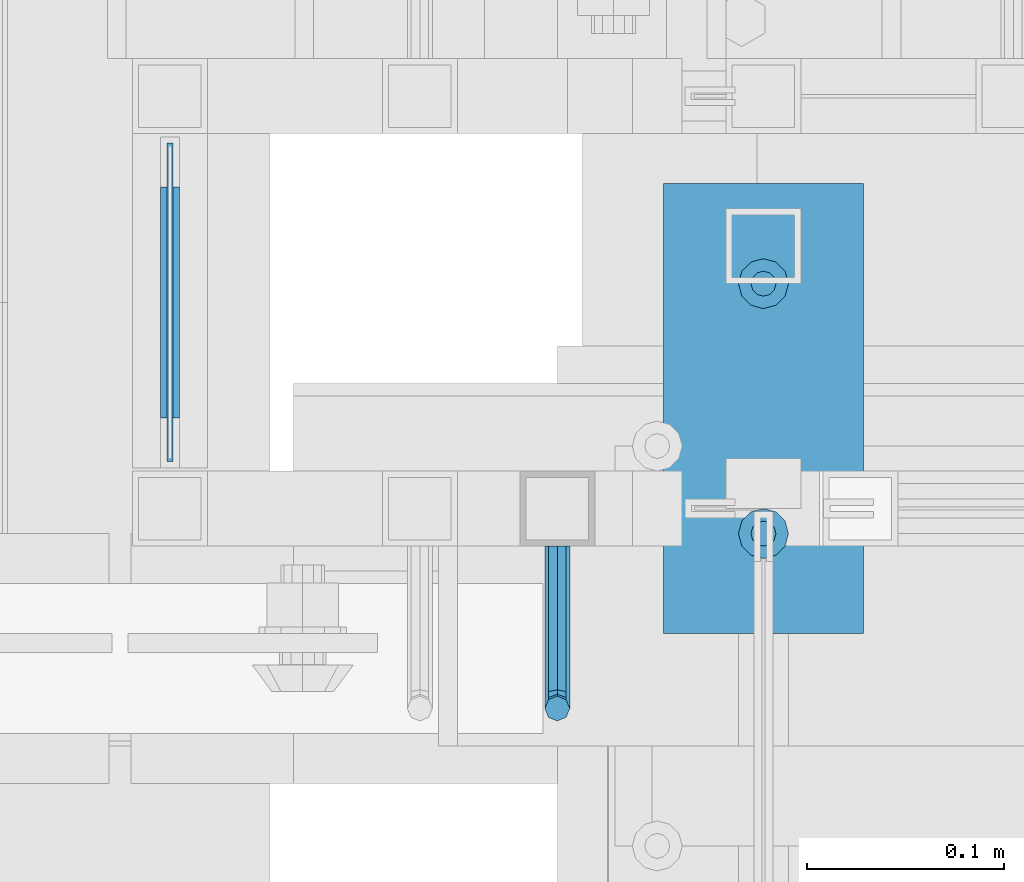
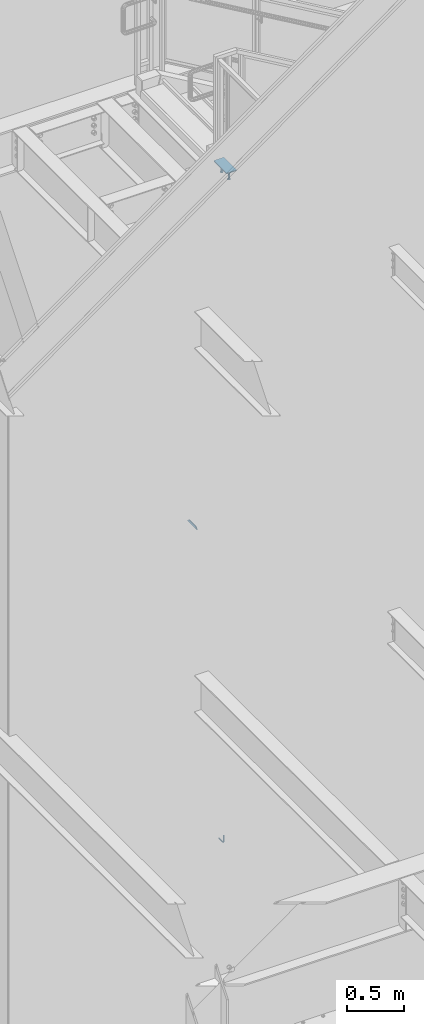
# One storey, part 907 of 1179: 5 beams, 3 elements without a shape of their own.
"""IFC2X3 building model written with IfcOpenShell, lengths in millimetres."""

from ifc_helpers import new_model, si_unit, frame, origin_with_axes, place, context, subcontext, project, spatial, faceted_brep, material, type_object, element, aggregate, save


model = new_model("IFC2X3")

# Units and contexts
model_context = context("Model", 3, precision=1e-05, world=origin_with_axes())
body_context = subcontext(model_context, "Body", "Model", "MODEL_VIEW")
ifc_project = project(units=[si_unit("LENGTHUNIT", "METRE", prefix="MILLI"), si_unit("AREAUNIT", "SQUARE_METRE"), si_unit("VOLUMEUNIT", "CUBIC_METRE"), si_unit("MASSUNIT", "GRAM", prefix="KILO"), si_unit("TIMEUNIT", "SECOND"), si_unit("PLANEANGLEUNIT", "RADIAN"), si_unit("SOLIDANGLEUNIT", "STERADIAN"), si_unit("THERMODYNAMICTEMPERATUREUNIT", "DEGREE_CELSIUS"), si_unit("LUMINOUSINTENSITYUNIT", "LUMEN")], contexts=[model_context])

# Site, building, storey
site_placement = place(None, origin_with_axes())
site = spatial("IfcSite", under=ifc_project, at=site_placement, CompositionType="ELEMENT")
building_placement = place(site_placement, origin_with_axes())
building = spatial("IfcBuilding", under=site, at=building_placement, Name="Undefined", CompositionType="ELEMENT")
storey_placement = place(building_placement, origin_with_axes())
storey = spatial("IfcBuildingStorey", under=building, at=storey_placement, Name="Undefined", CompositionType="ELEMENT", Elevation=0.0)

# Assembly, beam
assembly_1_placement = place(storey_placement, origin_with_axes())
assembly_1 = element("IfcElementAssembly", 1, at=assembly_1_placement, inside=storey, Name="GUARDRAIL", AssemblyPlace="NOTDEFINED", PredefinedType="RIGID_FRAME")
ifc_material_1 = material(Name="STEEL/BUY-OUT")
beam_type_1 = type_object("IfcBeamType", PredefinedType="NOTDEFINED")
beam_1_placement = place(assembly_1_placement, frame((19307.1749999845, 39563.6750015464, 4376.7375008146), z_axis=(0.0, -1.0, 0.0), x_axis=(0.0, 0.0, -1.0)))
beam_1 = element("IfcBeam", 2, at=beam_1_placement, type_object=beam_type_1, material=ifc_material_1, Name="U-EDGE", context=body_context, shape_type="Brep", body=[
    faceted_brep([(0.0, 1.58750000000146, 46.037500944738), (0.0, -1.58750000000146, 46.037500944738), (22.2250000381364, -1.58750000000146, 68.2625008571486), (22.2250000381364, -4.76249999999709, 68.2625008571486), (7.59955582907423e-08, -4.76249999999709, 46.0375010207354), (7.59955582907423e-08, -7.9375, 46.0375010207354), (25.4000000381357, -7.9375, 71.4375008391871), (25.4000000381357, 1.58750000000146, 71.4375008391871), (25.4000000381357, -7.9375, -96.8375000000015), (25.4000000381357, 1.58750000000146, -96.8375000000015), (0.0, 1.58750000000146, -71.4374998076601), (0.0, -1.58750000000146, -71.4374998076601), (22.2250000381364, -1.58750000000146, -93.6624999715204), (22.2250000381364, -4.76249999999709, -93.6624999715204), (7.59955582907423e-08, -4.76249999999709, -71.4374998836502), (7.59955582907423e-08, -7.9375, -71.4374998836502)], [[[0, 1, 2, 3, 4, 5, 6, 7]], [[7, 6, 8, 9]], [[0, 7, 9, 10]], [[1, 0, 10, 11]], [[2, 1, 11, 12]], [[3, 2, 12, 13]], [[4, 3, 13, 14]], [[5, 4, 14, 15]], [[6, 5, 15, 8]], [[14, 13, 12, 11, 10, 9, 8, 15]]]),
])
aggregate(assembly_1, [beam_1])

assembly_2_placement = place(storey_placement, origin_with_axes())
assembly_2 = element("IfcElementAssembly", 3, at=assembly_2_placement, inside=storey, Name="GUARDRAIL", AssemblyPlace="NOTDEFINED", PredefinedType="RIGID_FRAME")
ifc_material_2 = material(Name="STEEL/A36")
beam_type_2 = type_object("IfcBeamType", PredefinedType="NOTDEFINED")
beam_2_placement = place(assembly_2_placement, frame((19500.850000416, 39452.5499999814, 992.664373870646), z_axis=(0.0, 0.0, 1.0), x_axis=(0.0, -1.0, 0.0)))
beam_2 = element("IfcBeam", 4, at=beam_2_placement, type_object=beam_type_2, material=ifc_material_2, Name="BRACKET", context=body_context, shape_type="Brep", body=[
    faceted_brep([(0.0, 0.0, 6.34999999999991), (0.0, -4.49012806053361, 4.49012806053452), (69.849999425729, -4.49012806053361, 4.49012806053452), (69.849999425729, 0.0, 6.34999999999991), (0.0, 4.49012806053361, 4.49012806053452), (69.849999425729, 4.49012806053361, 4.49012806053452), (0.0, 6.34999999999854, 0.0), (69.849999425729, 6.34999999999854, 0.0), (0.0, 4.49012806053361, -4.49012806053452), (69.849999425729, 4.49012806053361, -4.49012806053452), (0.0, 0.0, -6.34999999999991), (69.849999425729, 0.0, -6.34999999999991), (0.0, -4.49012806053361, -4.49012806053452), (69.849999425729, -4.49012806053361, -4.49012806053452), (0.0, -6.34999999999854, 0.0), (69.849999425729, -6.34999999999854, 0.0), (76.1999993303689, -6.34999999999854, 1.70147734638658), (73.9549353000984, -4.49012806053361, 5.59004231305425), (73.024999330366, 0.0, 7.20073866041639), (73.9549353000984, 4.49012806053361, 5.59004231305425), (76.1999993303689, 6.34999999999854, 1.70147734638658), (78.445063360632, 4.49012806053361, -2.18708762028064), (79.3749993303718, 0.0, -3.79778396764323), (78.445063360632, -4.49012806053361, -2.18708762028064), (84.7370868552753, 4.49012806053361, 4.10493587436031), (87.0401272955278, 4.49012806053361, 12.6999998092651), (88.8999992349927, 0.0, 12.6999998092651), (86.3477832026401, 0.0, 3.17499990462693), (80.8485218886053, 6.34999999999854, 6.34999990462893), (82.5499992349942, 6.34999999999854, 12.6999998092651), (76.9599569219426, 4.49012806053361, 8.59506393489755), (78.0598711744606, 4.49012806053361, 12.6999998092651), (75.3492605745778, 0.0, 9.52499990463093), (76.1999992349956, 0.0, 12.6999998092651), (76.9599569219426, -4.49012806053361, 8.59506393489755), (78.0598711744606, -4.49012806053361, 12.6999998092651), (80.8485218886053, -6.34999999999854, 6.34999990462893), (82.5499992349942, -6.34999999999854, 12.6999998092651), (84.7370868552753, -4.49012806053361, 4.10493587436031), (87.0401272955278, -4.49012806053361, 12.6999998092651), (88.8999992349927, 0.0, 76.2000000000003), (87.0401280961523, -4.4901280621234, 73.5807586148453), (82.5500000355751, -6.35000000147556, 72.4958333104305), (78.0598719750778, -4.4901280619415, 73.5807586149517), (76.1999992349956, 0.0, 76.2000000000003), (78.0598719752597, 4.49012805902021, 78.8192413833694), (82.550000035837, 6.34999999837237, 79.9041666931562), (87.0401280963342, 4.49012805883831, 78.819241383263)], [[[0, 1, 2, 3]], [[4, 0, 3, 5]], [[6, 4, 5, 7]], [[8, 6, 7, 9]], [[10, 8, 9, 11]], [[12, 10, 11, 13]], [[1, 0, 4, 6, 8, 10, 12, 14]], [[1, 14, 15, 2]], [[14, 12, 13, 15]], [[2, 15, 16, 17]], [[3, 2, 17, 18]], [[5, 3, 18, 19]], [[7, 5, 19, 20]], [[9, 7, 20, 21]], [[11, 9, 21, 22]], [[13, 11, 22, 23]], [[24, 25, 26, 27]], [[28, 29, 25, 24]], [[30, 31, 29, 28]], [[32, 33, 31, 30]], [[34, 35, 33, 32]], [[36, 37, 35, 34]], [[38, 39, 37, 36]], [[27, 26, 39, 38]], [[22, 27, 38, 23]], [[21, 24, 27, 22]], [[20, 28, 24, 21]], [[19, 30, 28, 20]], [[18, 32, 30, 19]], [[17, 34, 32, 18]], [[16, 36, 34, 17]], [[23, 38, 36, 16]], [[15, 13, 23, 16]], [[39, 26, 40, 41]], [[37, 39, 41, 42]], [[35, 37, 42, 43]], [[33, 35, 43, 44]], [[31, 33, 44, 45]], [[29, 31, 45, 46]], [[25, 29, 46, 47]], [[26, 25, 47, 40]], [[46, 45, 44, 43, 42, 41, 40, 47]]]),
])
aggregate(assembly_2, [beam_2])

# Assembly, beams
assembly_3_placement = place(storey_placement, origin_with_axes())
assembly_3 = element("IfcElementAssembly", 5, at=assembly_3_placement, inside=storey, Name="EMBED", AssemblyPlace="NOTDEFINED", PredefinedType="RIGID_FRAME")
ifc_material_3 = material(Name="STEEL/A108")
beam_type_3 = type_object("IfcBeamType", Name="STUD_1/2-DIA", PredefinedType="NOTDEFINED")
beam_3_placement = place(assembly_3_placement, frame((19605.625, 39458.900000798, 8137.525), z_axis=(0.0, -1.0, 0.0), x_axis=(0.0, 0.0, -1.0)))
beam_3 = element("IfcBeam", 6, at=beam_3_placement, type_object=beam_type_3, material=ifc_material_3, Name="SHEAR STUD", ObjectType="STUD_1/2-DIA", context=body_context, shape_type="Brep", body=[
    faceted_brep([(0.0, -3.1800000667572, 5.5), (0.0, -5.5, 3.1800000667572), (94.4880000000003, -5.5, 3.1800000667572), (94.4880000000003, -3.1800000667572, 5.5), (0.0, -6.34999999999854, 0.0), (94.4880000000003, -6.34999990463257, 0.0), (0.0, -5.5, -3.1800000667572), (94.4880000000003, -5.5, -3.1800000667572), (0.0, -3.1800000667572, -5.5), (94.4880000000003, -3.1800000667572, -5.5), (0.0, 0.0, -6.34999999999991), (94.4880000000003, 0.0, -6.34999990463257), (0.0, 3.1800000667572, -5.5), (94.4880000000003, 3.1800000667572, -5.5), (0.0, 5.5, -3.1800000667572), (94.4880000000003, 5.5, -3.1800000667572), (0.0, 6.34999999999854, 0.0), (94.4880000000003, 6.34999990463257, 0.0), (0.0, 5.5, 3.1800000667572), (94.4880000000003, 5.5, 3.1800000667572), (0.0, 3.1800000667572, 5.5), (94.4880000000003, 3.1800000667572, 5.5), (0.0, 0.0, 6.34999999999991), (94.4880000000003, 0.0, 6.34999990463257), (96.5200000000004, -10.9899997711182, 6.34999990463257), (96.5200000000004, -6.34000015258789, 10.9899997711182), (96.5200000000004, -12.6999998092651, 0.0), (96.5200000000004, -10.9899997711182, -6.34999990463257), (96.5200000000004, -6.34000015258789, -10.9899997711182), (96.5200000000004, 0.0, -12.6899995803833), (96.5200000000004, 6.34000015258789, -10.9899997711182), (96.5200000000004, 10.9899997711182, -6.34999990463257), (96.5200000000004, 12.6999998092651, 0.0), (96.5200000000004, 10.9899997711182, 6.34999990463257), (96.5200000000004, 6.34000015258789, 10.9899997711182), (96.5200000000004, 0.0, 12.6899995803833), (101.6, -10.9899997711182, 6.34999990463257), (101.6, -6.34000015258789, 10.9899997711182), (101.6, -12.6999998092651, 0.0), (101.6, -10.9899997711182, -6.34999990463257), (101.6, -6.34000015258789, -10.9899997711182), (101.6, 0.0, -12.6899995803833), (101.6, 6.34000015258789, -10.9899997711182), (101.6, 10.9899997711182, -6.34999990463257), (101.6, 12.6999998092651, 0.0), (101.6, 10.9899997711182, 6.34999990463257), (101.6, 6.34000015258789, 10.9899997711182), (101.6, 0.0, 12.6899995803833)], [[[0, 1, 2, 3]], [[1, 4, 5, 2]], [[4, 6, 7, 5]], [[6, 8, 9, 7]], [[8, 10, 11, 9]], [[10, 12, 13, 11]], [[12, 14, 15, 13]], [[14, 16, 17, 15]], [[16, 18, 19, 17]], [[18, 20, 21, 19]], [[20, 22, 23, 21]], [[22, 0, 3, 23]], [[22, 20, 18, 16, 14, 12, 10, 8, 6, 4, 1, 0]], [[3, 2, 24, 25]], [[2, 5, 26, 24]], [[5, 7, 27, 26]], [[7, 9, 28, 27]], [[9, 11, 29, 28]], [[11, 13, 30, 29]], [[13, 15, 31, 30]], [[15, 17, 32, 31]], [[17, 19, 33, 32]], [[19, 21, 34, 33]], [[21, 23, 35, 34]], [[23, 3, 25, 35]], [[25, 24, 36, 37]], [[24, 26, 38, 36]], [[26, 27, 39, 38]], [[27, 28, 40, 39]], [[28, 29, 41, 40]], [[29, 30, 42, 41]], [[30, 31, 43, 42]], [[31, 32, 44, 43]], [[32, 33, 45, 44]], [[33, 34, 46, 45]], [[34, 35, 47, 46]], [[35, 25, 37, 47]], [[38, 39, 40, 41, 42, 43, 44, 45, 46, 47, 37, 36]]]),
])
beam_4_placement = place(assembly_3_placement, frame((19605.625, 39585.900000798, 8137.525), z_axis=(0.0, -1.0, 0.0), x_axis=(0.0, 0.0, -1.0)))
beam_4 = element("IfcBeam", 7, at=beam_4_placement, type_object=beam_type_3, material=ifc_material_3, Name="SHEAR STUD", ObjectType="STUD_1/2-DIA", context=body_context, shape_type="Brep", body=[
    faceted_brep([(0.0, -3.1800000667572, 5.5), (0.0, -5.5, 3.1800000667572), (94.4880000000003, -5.5, 3.1800000667572), (94.4880000000003, -3.1800000667572, 5.5), (0.0, -6.34999999999854, 0.0), (94.4880000000003, -6.34999990463257, 0.0), (0.0, -5.5, -3.1800000667572), (94.4880000000003, -5.5, -3.1800000667572), (0.0, -3.1800000667572, -5.5), (94.4880000000003, -3.1800000667572, -5.5), (0.0, 0.0, -6.34999999999991), (94.4880000000003, 0.0, -6.34999990463257), (0.0, 3.1800000667572, -5.5), (94.4880000000003, 3.1800000667572, -5.5), (0.0, 5.5, -3.1800000667572), (94.4880000000003, 5.5, -3.1800000667572), (0.0, 6.34999999999854, 0.0), (94.4880000000003, 6.34999990463257, 0.0), (0.0, 5.5, 3.1800000667572), (94.4880000000003, 5.5, 3.1800000667572), (0.0, 3.1800000667572, 5.5), (94.4880000000003, 3.1800000667572, 5.5), (0.0, 0.0, 6.34999999999991), (94.4880000000003, 0.0, 6.34999990463257), (96.5200000000004, -10.9899997711182, 6.34999990463257), (96.5200000000004, -6.34000015258789, 10.9899997711182), (96.5200000000004, -12.6999998092651, 0.0), (96.5200000000004, -10.9899997711182, -6.34999990463257), (96.5200000000004, -6.34000015258789, -10.9899997711182), (96.5200000000004, 0.0, -12.6899995803833), (96.5200000000004, 6.34000015258789, -10.9899997711182), (96.5200000000004, 10.9899997711182, -6.34999990463257), (96.5200000000004, 12.6999998092651, 0.0), (96.5200000000004, 10.9899997711182, 6.34999990463257), (96.5200000000004, 6.34000015258789, 10.9899997711182), (96.5200000000004, 0.0, 12.6899995803833), (101.6, -10.9899997711182, 6.34999990463257), (101.6, -6.34000015258789, 10.9899997711182), (101.6, -12.6999998092651, 0.0), (101.6, -10.9899997711182, -6.34999990463257), (101.6, -6.34000015258789, -10.9899997711182), (101.6, 0.0, -12.6899995803833), (101.6, 6.34000015258789, -10.9899997711182), (101.6, 10.9899997711182, -6.34999990463257), (101.6, 12.6999998092651, 0.0), (101.6, 10.9899997711182, 6.34999990463257), (101.6, 6.34000015258789, 10.9899997711182), (101.6, 0.0, 12.6899995803833)], [[[0, 1, 2, 3]], [[1, 4, 5, 2]], [[4, 6, 7, 5]], [[6, 8, 9, 7]], [[8, 10, 11, 9]], [[10, 12, 13, 11]], [[12, 14, 15, 13]], [[14, 16, 17, 15]], [[16, 18, 19, 17]], [[18, 20, 21, 19]], [[20, 22, 23, 21]], [[22, 0, 3, 23]], [[22, 20, 18, 16, 14, 12, 10, 8, 6, 4, 1, 0]], [[3, 2, 24, 25]], [[2, 5, 26, 24]], [[5, 7, 27, 26]], [[7, 9, 28, 27]], [[9, 11, 29, 28]], [[11, 13, 30, 29]], [[13, 15, 31, 30]], [[15, 17, 32, 31]], [[17, 19, 33, 32]], [[19, 21, 34, 33]], [[21, 23, 35, 34]], [[23, 3, 25, 35]], [[25, 24, 36, 37]], [[24, 26, 38, 36]], [[26, 27, 39, 38]], [[27, 28, 40, 39]], [[28, 29, 41, 40]], [[29, 30, 42, 41]], [[30, 31, 43, 42]], [[31, 32, 44, 43]], [[32, 33, 45, 44]], [[33, 34, 46, 45]], [[34, 35, 47, 46]], [[35, 25, 37, 47]], [[38, 39, 40, 41, 42, 43, 44, 45, 46, 47, 37, 36]]]),
])
beam_type_4 = type_object("IfcBeamType", PredefinedType="NOTDEFINED")
beam_5_placement = place(assembly_3_placement, frame((19605.625, 39636.700000798, 8142.2875), z_axis=(1.0, 0.0, 0.0), x_axis=(0.0, -1.0, 0.0)))
beam_5 = element("IfcBeam", 8, at=beam_5_placement, type_object=beam_type_4, material=ifc_material_2, Name="EMBED", context=body_context, shape_type="Brep", body=[
    faceted_brep([(0.0, 4.76249999999982, -50.7999999999993), (0.0, 4.76249999999982, 50.7999999999993), (228.599999999999, 4.76249999999982, 50.7999999999993), (228.599999999999, 4.76249999999982, -50.7999999999993), (0.0, -4.76249999999982, 50.7999999999993), (228.599999999999, -4.76249999999982, 50.7999999999993), (0.0, -4.76249999999982, -50.7999999999993), (228.599999999999, -4.76249999999982, -50.7999999999993)], [[[0, 1, 2, 3]], [[1, 4, 5, 2]], [[4, 6, 7, 5]], [[6, 0, 3, 7]], [[5, 7, 3, 2]], [[6, 4, 1, 0]]]),
])
aggregate(assembly_3, [beam_3, beam_4, beam_5])

save(model, "model.ifc")
